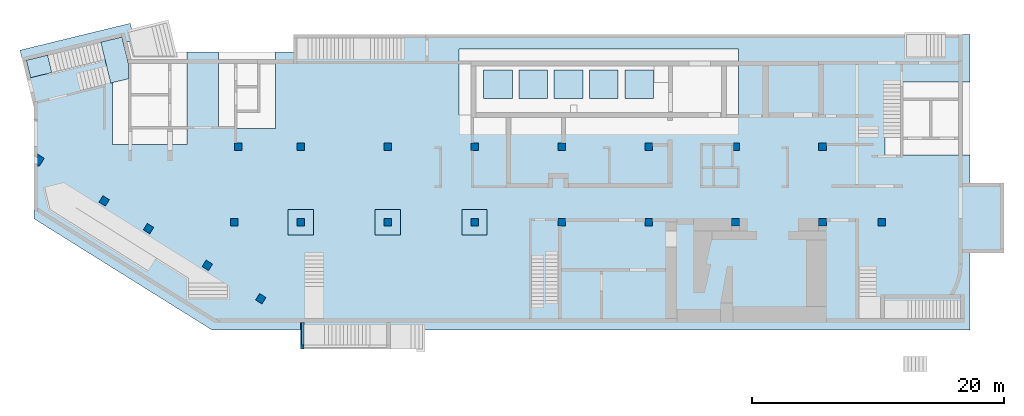
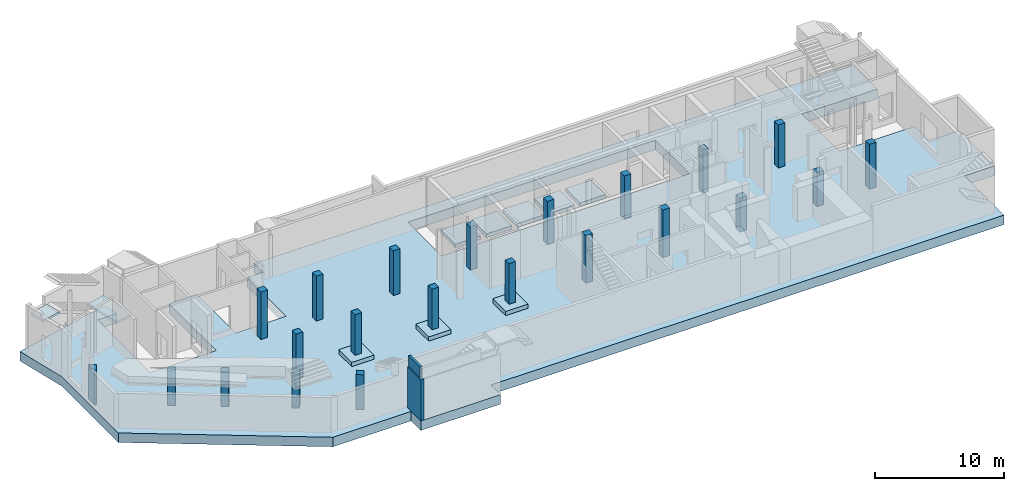
# One storey, part 1 of 9: 22 columns, 11 slabs, 2 walls.
"""IFC4 building model written with IfcOpenShell, lengths in millimetres."""

import ifcopenshell
import ifcopenshell.guid

model = None  # the IFC model being written
_history = None  # IfcOwnerHistory: only IFC2X3 demands one
_inside = {}  # id of a spatial element -> (the spatial element, [elements in it])
_under = {}  # id of a project, library or spatial element -> (it, [spatial elements below it])
_declared = {}  # id of a project -> (the project, [libraries it declares])
_typed = {}  # id of a type object -> (the type object, [elements of that type])
_made_of = {}  # id of a material, layer set ... -> (it, [elements and type objects made of it])


def new_model(schema):
    """Start an empty IFC model of exactly this schema.

    Asked for "IFC4X3", IfcOpenShell would pick the latest addendum, in which some entities
    have other attributes; the version numbers below select the first issue.
    IFC2X3 requires an IfcOwnerHistory on every rooted entity: one is made here for all.
    """
    global model, _history
    if schema == "IFC4X3":
        model = ifcopenshell.file(schema_version=(4, 3, 0, 0))
    else:
        model = ifcopenshell.file(schema=schema)
    _inside.clear()
    _under.clear()
    _declared.clear()
    _typed.clear()
    _made_of.clear()
    _history = None
    if model.schema == "IFC2X3":
        org = make("IfcOrganization", Name="unknown")
        user = make(
            "IfcPersonAndOrganization",
            ThePerson=make("IfcPerson", FamilyName="unknown"),
            TheOrganization=org,
        )
        app = make(
            "IfcApplication",
            ApplicationDeveloper=org,
            Version="unknown",
            ApplicationFullName="unknown",
            ApplicationIdentifier="unknown",
        )
        _history = make(
            "IfcOwnerHistory",
            OwningUser=user,
            OwningApplication=app,
            ChangeAction="ADDED",
            CreationDate=0,
        )
    return model


def make(cls, **values):
    """One entity of the class cls with the attributes given. An attribute that is None is left unset."""
    return model.create_entity(
        cls, **{name: value for name, value in values.items() if value is not None}
    )


def entity(cls, *values):
    """Any entity or typed value of the class cls, its attributes in the order of the schema. None: left unset."""
    e = model.create_entity(cls)
    for i, value in enumerate(values):
        if value is not None:
            e[i] = value
    return e


def rooted(cls, **values):
    """An entity with a GlobalId (a new one), such as an element, a storey or a relation."""
    return make(cls, GlobalId=ifcopenshell.guid.new(), OwnerHistory=_history, **values)


def si_unit(unit_type, name, prefix=None):
    """IfcSIUnit, for example si_unit("LENGTHUNIT", "METRE", prefix="MILLI")."""
    return make("IfcSIUnit", UnitType=unit_type, Prefix=prefix, Name=name)


def converted_unit(unit_type, name, factor, base, dimensions=None, offset=None):
    """IfcConversionBasedUnit, such as the inch: factor (a typed value) times the base unit."""
    return make(
        "IfcConversionBasedUnit"
        if offset is None
        else "IfcConversionBasedUnitWithOffset",
        ConversionOffset=offset,
        Dimensions=None
        if dimensions is None
        else entity("IfcDimensionalExponents", *dimensions),
        UnitType=unit_type,
        Name=name,
        ConversionFactor=make(
            "IfcMeasureWithUnit", ValueComponent=factor, UnitComponent=base
        ),
    )


def derived_unit(unit_type, elements):
    """IfcDerivedUnit: a product of units, each with its exponent."""
    return make(
        "IfcDerivedUnit",
        Elements=[
            make("IfcDerivedUnitElement", Unit=unit, Exponent=power)
            for unit, power in elements
        ],
        UnitType=unit_type,
    )


def assignment(units):
    """IfcUnitAssignment: the units of a project."""
    return None if units is None else make("IfcUnitAssignment", Units=units)


def point(xyz):
    """IfcCartesianPoint."""
    return None if xyz is None else make("IfcCartesianPoint", Coordinates=xyz)


def direction(xyz):
    """IfcDirection."""
    return None if xyz is None else make("IfcDirection", DirectionRatios=xyz)


def frame(location, z_axis=None, x_axis=None):
    """IfcAxis2Placement3D, a coordinate frame: its origin and axes. An axis left out is left unset."""
    return make(
        "IfcAxis2Placement3D",
        Location=point(location),
        Axis=direction(z_axis),
        RefDirection=direction(x_axis),
    )


def origin():
    """The frame at (0, 0, 0) with its axes left unset."""
    return frame((0.0, 0.0, 0.0))


def place(relative_to, where):
    """IfcLocalPlacement: puts the frame where relative to a parent placement (None: the world)."""
    return make(
        "IfcLocalPlacement", PlacementRelTo=relative_to, RelativePlacement=where
    )


def context(
    kind, dimensions, precision=None, world=None, true_north=None, identifier=None
):
    """IfcGeometricRepresentationContext, for example the 3D "Model" context."""
    return make(
        "IfcGeometricRepresentationContext",
        ContextIdentifier=identifier,
        ContextType=kind,
        CoordinateSpaceDimension=dimensions,
        Precision=precision,
        WorldCoordinateSystem=world,
        TrueNorth=true_north,
    )


def subcontext(parent, identifier, kind, view, scale=None):
    """IfcGeometricRepresentationSubContext, for example "Body" below "Model"."""
    return make(
        "IfcGeometricRepresentationSubContext",
        ContextIdentifier=identifier,
        ContextType=kind,
        ParentContext=parent,
        TargetScale=scale,
        TargetView=view,
    )


def project(units=None, contexts=None):
    """IfcProject with its units and contexts."""
    return rooted(
        "IfcProject",
        Name="project",
        RepresentationContexts=contexts,
        UnitsInContext=assignment(units),
    )


def spatial(cls, under=None, at=None, **own):
    """A site, building, storey or space (cls), placed at a placement, below another one or the project."""
    s = rooted(cls, ObjectPlacement=at, **own)
    if under is not None:
        _under.setdefault(under.id(), (under, []))[1].append(s)
    return s


def point_list(points):
    """IfcCartesianPointList2D or 3D."""
    cls = (
        "IfcCartesianPointList2D" if len(points[0]) == 2 else "IfcCartesianPointList3D"
    )
    return make(cls, CoordList=points)


def indexed_curve(points, segments=None, self_intersect=None):
    """IfcIndexedPolyCurve: lines and arcs through numbered points (the first is 1)."""
    return make(
        "IfcIndexedPolyCurve",
        Points=point_list(points),
        Segments=segments,
        SelfIntersect=self_intersect,
    )


def outline(outer, holes=None, kind="AREA"):
    """IfcArbitraryClosedProfileDef: a profile drawn as a closed curve; with holes, ...WithVoids."""
    if holes is None:
        return make("IfcArbitraryClosedProfileDef", ProfileType=kind, OuterCurve=outer)
    return make(
        "IfcArbitraryProfileDefWithVoids",
        ProfileType=kind,
        OuterCurve=outer,
        InnerCurves=holes,
    )


def extrude(swept, where, along, depth):
    """IfcExtrudedAreaSolid: the profile swept, set in the frame where, extruded along a direction by depth."""
    return make(
        "IfcExtrudedAreaSolid",
        SweptArea=swept,
        Position=where,
        ExtrudedDirection=direction(along),
        Depth=depth,
    )


def shape(context_of_items, identifier, shape_type, items):
    """IfcShapeRepresentation: the items that make up one representation, for example the "Body"."""
    return make(
        "IfcShapeRepresentation",
        ContextOfItems=context_of_items,
        RepresentationIdentifier=identifier,
        RepresentationType=shape_type,
        Items=items,
    )


def source(mapping_origin, context_of_items, identifier, shape_type, items):
    """IfcRepresentationMap: a shape defined once, which mapped items show again and again."""
    return make(
        "IfcRepresentationMap",
        MappingOrigin=mapping_origin,
        MappedRepresentation=shape(context_of_items, identifier, shape_type, items),
    )


def transform(
    local_origin,
    x_axis=None,
    y_axis=None,
    z_axis=None,
    scale=None,
    scale2=None,
    scale3=None,
    uniform=True,
):
    """IfcCartesianTransformationOperator3D, or its non-uniform kind. x_axis, y_axis, z_axis: its Axis1, 2, 3."""
    if uniform:
        return make(
            "IfcCartesianTransformationOperator3D",
            Axis1=direction(x_axis),
            Axis2=direction(y_axis),
            LocalOrigin=point(local_origin),
            Scale=scale,
            Axis3=direction(z_axis),
        )
    return make(
        "IfcCartesianTransformationOperator3DnonUniform",
        Axis1=direction(x_axis),
        Axis2=direction(y_axis),
        LocalOrigin=point(local_origin),
        Scale=scale,
        Axis3=direction(z_axis),
        Scale2=scale2,
        Scale3=scale3,
    )


def mapped(mapping_source, mapping_target):
    """IfcMappedItem: shows the shape of a source again, moved by a transform."""
    return make(
        "IfcMappedItem", MappingSource=mapping_source, MappingTarget=mapping_target
    )


def material(Name=None, Category=None):
    """IfcMaterial."""
    return make("IfcMaterial", Name=Name, Category=Category)


def constituent(of_material, Name=None, Category=None, fraction=None):
    """IfcMaterialConstituent: one of the materials an element consists of."""
    return make(
        "IfcMaterialConstituent",
        Name=Name,
        Material=of_material,
        Fraction=fraction,
        Category=Category,
    )


def constituent_set(constituents=None, Name=None):
    """IfcMaterialConstituentSet."""
    return make(
        "IfcMaterialConstituentSet", Name=Name, MaterialConstituents=constituents
    )


def made_of(thing, what):
    """Note that an element or type object is made of a material, layer set ...; save() writes the relation."""
    if what is not None:
        _made_of.setdefault(what.id(), (what, []))[1].append(thing)
    return thing


def type_object(cls, material=None, **own):
    """A type object (cls), such as IfcWallType, which elements share."""
    return made_of(rooted(cls, **own), material)


def type_shapes(of_type, sources):
    """Give a type object the sources (RepresentationMaps) that its elements show as mapped items."""
    of_type.RepresentationMaps = sources


def element(
    cls,
    number,
    at=None,
    inside=None,
    cuts=None,
    type_object=None,
    material=None,
    context=None,
    identifier="Body",
    shape_type=None,
    held_by="IfcProductDefinitionShape",
    body=None,
    shapes=None,
    **own,
):
    """One element of the class cls, such as IfcWall. Its Tag is "e" and its number.

    at: its placement. inside: the storey or other place that contains it. cuts: it is an
    opening in that element (IfcRelVoidsElement). A single representation is given by context,
    identifier, shape_type and body (its items); several are given by shapes. held_by: the class
    of the entity that holds the representations. save() writes the other relations.
    """
    e = rooted(cls, Tag="e%d" % number, ObjectPlacement=at, **own)
    if body is not None:
        shapes = [shape(context, identifier, shape_type, body)]
    if shapes is not None:
        e.Representation = make(held_by, Representations=shapes)
    if inside is not None:
        _inside.setdefault(inside.id(), (inside, []))[1].append(e)
    if cuts is not None:
        rooted(
            "IfcRelVoidsElement", RelatingBuildingElement=cuts, RelatedOpeningElement=e
        )
    if type_object is not None:
        _typed.setdefault(type_object.id(), (type_object, []))[1].append(e)
    return made_of(e, material)


def aggregate(whole, parts):
    """IfcRelAggregates: a whole, such as a stair, and the parts it consists of."""
    return rooted("IfcRelAggregates", RelatingObject=whole, RelatedObjects=parts)


def save(model, path):
    """Write the relations noted so far, then the file.

    IfcRelAggregates (storeys below a building ...), IfcRelContainedInSpatialStructure (elements
    in a storey), IfcRelDefinesByType, IfcRelAssociatesMaterial and IfcRelDeclares: one each for
    every whole, place, type object, material and project.
    """
    for whole, parts in _under.values():
        aggregate(whole, parts)
    for where, things in _inside.values():
        rooted(
            "IfcRelContainedInSpatialStructure",
            RelatedElements=things,
            RelatingStructure=where,
        )
    for kind, things in _typed.values():
        rooted("IfcRelDefinesByType", RelatedObjects=things, RelatingType=kind)
    for what, things in _made_of.values():
        rooted("IfcRelAssociatesMaterial", RelatedObjects=things, RelatingMaterial=what)
    for by, libraries in _declared.values():
        rooted("IfcRelDeclares", RelatingContext=by, RelatedDefinitions=libraries)
    model.write(path)


model = new_model("IFC4")

# Units and contexts
model_context = context("Model", 3, precision=0.01, world=origin(), true_north=direction((6.12303176911189e-17, 1.0)))
plan_context = context("Plan", 3, precision=0.01, world=origin(), true_north=direction((6.12303176911189e-17, 1.0)))
body_context = subcontext(model_context, "Body", "Model", "MODEL_VIEW")
ifc_project = project(units=[si_unit("LENGTHUNIT", "METRE", prefix="MILLI"), si_unit("AREAUNIT", "SQUARE_METRE"), si_unit("VOLUMEUNIT", "CUBIC_METRE"), converted_unit("PLANEANGLEUNIT", "DEGREE", entity("IfcRatioMeasure", 0.0174532925199433), si_unit("PLANEANGLEUNIT", "RADIAN"), dimensions=[0, 0, 0, 0, 0, 0, 0]), si_unit("MASSUNIT", "GRAM", prefix="KILO"), derived_unit("MASSDENSITYUNIT", [(si_unit("MASSUNIT", "GRAM", prefix="KILO"), 1), (si_unit("LENGTHUNIT", "METRE"), -3)]), derived_unit("MOMENTOFINERTIAUNIT", [(si_unit("LENGTHUNIT", "METRE"), 4)]), si_unit("TIMEUNIT", "SECOND"), si_unit("FREQUENCYUNIT", "HERTZ"), si_unit("THERMODYNAMICTEMPERATUREUNIT", "DEGREE_CELSIUS"), derived_unit("THERMALTRANSMITTANCEUNIT", [(si_unit("MASSUNIT", "GRAM", prefix="KILO"), 1), (si_unit("THERMODYNAMICTEMPERATUREUNIT", "KELVIN"), -1), (si_unit("TIMEUNIT", "SECOND"), -3)]), derived_unit("VOLUMETRICFLOWRATEUNIT", [(si_unit("LENGTHUNIT", "METRE"), 3), (si_unit("TIMEUNIT", "SECOND"), -1)]), derived_unit("MASSFLOWRATEUNIT", [(si_unit("MASSUNIT", "GRAM", prefix="KILO"), 1), (si_unit("TIMEUNIT", "SECOND"), -1)]), derived_unit("ROTATIONALFREQUENCYUNIT", [(si_unit("TIMEUNIT", "SECOND"), -1)]), si_unit("ELECTRICCURRENTUNIT", "AMPERE"), si_unit("ELECTRICVOLTAGEUNIT", "VOLT"), si_unit("POWERUNIT", "WATT"), si_unit("FORCEUNIT", "NEWTON", prefix="KILO"), si_unit("ILLUMINANCEUNIT", "LUX"), si_unit("LUMINOUSFLUXUNIT", "LUMEN"), si_unit("LUMINOUSINTENSITYUNIT", "CANDELA"), derived_unit("USERDEFINED", [(si_unit("MASSUNIT", "GRAM", prefix="KILO"), -1), (si_unit("LENGTHUNIT", "METRE"), -2), (si_unit("TIMEUNIT", "SECOND"), 3), (si_unit("LUMINOUSFLUXUNIT", "LUMEN"), 1)]), derived_unit("LINEARVELOCITYUNIT", [(si_unit("LENGTHUNIT", "METRE"), 1), (si_unit("TIMEUNIT", "SECOND"), -1)]), si_unit("PRESSUREUNIT", "PASCAL"), derived_unit("USERDEFINED", [(si_unit("LENGTHUNIT", "METRE"), -2), (si_unit("MASSUNIT", "GRAM", prefix="KILO"), 1), (si_unit("TIMEUNIT", "SECOND"), -2)]), derived_unit("LINEARFORCEUNIT", [(si_unit("MASSUNIT", "GRAM", prefix="KILO"), 1), (si_unit("LENGTHUNIT", "METRE"), 1), (si_unit("TIMEUNIT", "SECOND"), -2), (si_unit("LENGTHUNIT", "METRE"), -1)]), derived_unit("PLANARFORCEUNIT", [(si_unit("MASSUNIT", "GRAM", prefix="KILO"), 1), (si_unit("LENGTHUNIT", "METRE"), 1), (si_unit("TIMEUNIT", "SECOND"), -2), (si_unit("LENGTHUNIT", "METRE"), -2)])], contexts=[model_context, plan_context])

# Site, building, storey
site_placement = place(None, origin())
site = spatial("IfcSite", under=ifc_project, at=site_placement, CompositionType="ELEMENT")
building_placement = place(site_placement, origin())
building = spatial("IfcBuilding", under=site, at=building_placement, CompositionType="ELEMENT")
storey_placement = place(building_placement, frame((0.0, 0.0, -4900.0)))
storey = spatial("IfcBuildingStorey", under=building, at=storey_placement, CompositionType="ELEMENT", Elevation=-4900.0)

# Columns
ifc_material_1 = material()
column_type_1 = type_object("IfcColumnType", PredefinedType="COLUMN", material=ifc_material_1)
shared_shape_1 = source(origin(), body_context, "Body", "SweptSolid", [
    extrude(outline(indexed_curve([(-300.0, -300.000000000001), (300.0, -300.000000000001), (300.0, 299.999999999999), (-300.0, 299.999999999999), (-300.0, -300.000000000001)], self_intersect=False)), frame((15900.0002685547, 7699.99922635634, -4900.0), z_axis=(0.0, 0.0, 1.0), x_axis=(0.0, -1.0, 0.0)), (0.0, 0.0, 1.0), 4250.0),
])
type_shapes(column_type_1, [shared_shape_1])
column_1_placement = place(storey_placement, frame((0.0, 0.0, 4900.0)))
element("IfcColumn", 1, at=column_1_placement, inside=storey, type_object=column_type_1, PredefinedType="COLUMN", context=body_context, shape_type="MappedRepresentation", body=[
    mapped(shared_shape_1, transform((0.0, 0.0, 0.0), scale=1.0)),
])
column_type_2 = type_object("IfcColumnType", PredefinedType="COLUMN", material=ifc_material_1)
shared_shape_2 = source(origin(), body_context, "Body", "SweptSolid", [
    extrude(outline(indexed_curve([(-300.000000000001, -300.000000000001), (299.999999999999, -300.000000000001), (299.999999999999, 299.999999999999), (-300.000000000001, 299.999999999999), (-300.000000000001, -300.000000000001)], self_intersect=False)), frame((16200.0002685547, 13699.9992263563, -4900.0), z_axis=(0.0, 0.0, 1.0), x_axis=(0.0, -1.0, 0.0)), (0.0, 0.0, 1.0), 4500.0),
])
type_shapes(column_type_2, [shared_shape_2])
column_2_placement = place(storey_placement, frame((0.0, 0.0, 4900.0)))
element("IfcColumn", 2, at=column_2_placement, inside=storey, type_object=column_type_2, PredefinedType="COLUMN", context=body_context, shape_type="MappedRepresentation", body=[
    mapped(shared_shape_2, transform((0.0, 0.0, 0.0), scale=1.0)),
])
column_type_3 = type_object("IfcColumnType", PredefinedType="COLUMN", material=ifc_material_1)
shared_shape_3 = source(origin(), body_context, "Body", "SweptSolid", [
    extrude(outline(indexed_curve([(-299.999999999999, -300.000000000001), (300.000000000001, -300.000000000001), (299.999999999999, 299.999999999997), (-300.000000000001, 300.000000000001), (-299.999999999999, -300.000000000001)], self_intersect=False)), frame((21170.0002685547, 13699.9992263563, -4900.0), z_axis=(0.0, 0.0, 1.0), x_axis=(0.0, -1.0, 0.0)), (0.0, 0.0, 1.0), 4250.0),
])
type_shapes(column_type_3, [shared_shape_3])
column_3_placement = place(storey_placement, frame((0.0, 0.0, 4900.0)))
element("IfcColumn", 3, at=column_3_placement, inside=storey, type_object=column_type_3, PredefinedType="COLUMN", context=body_context, shape_type="MappedRepresentation", body=[
    mapped(shared_shape_3, transform((0.0, 0.0, 0.0), scale=1.0)),
])
column_type_4 = type_object("IfcColumnType", PredefinedType="COLUMN", material=ifc_material_1)
shared_shape_4 = source(origin(), body_context, "Body", "SweptSolid", [
    extrude(outline(indexed_curve([(-299.999999999997, -300.000000000001), (300.000000000003, -300.000000000001), (300.000000000001, 299.999999999997), (-299.999999999999, 300.000000000001), (-299.999999999997, -300.000000000001)], self_intersect=False)), frame((28070.0002685547, 13699.9992263563, -4900.0), z_axis=(0.0, 0.0, 1.0), x_axis=(0.0, -1.0, 0.0)), (0.0, 0.0, 1.0), 4250.0),
])
type_shapes(column_type_4, [shared_shape_4])
column_4_placement = place(storey_placement, frame((0.0, 0.0, 4900.0)))
element("IfcColumn", 4, at=column_4_placement, inside=storey, type_object=column_type_4, PredefinedType="COLUMN", context=body_context, shape_type="MappedRepresentation", body=[
    mapped(shared_shape_4, transform((0.0, 0.0, 0.0), scale=1.0)),
])
column_type_5 = type_object("IfcColumnType", PredefinedType="COLUMN", material=ifc_material_1)
shared_shape_5 = source(origin(), body_context, "Body", "SweptSolid", [
    extrude(outline(indexed_curve([(-299.999999999999, -300.000000000001), (300.000000000001, -300.000000000001), (299.999999999999, 299.999999999997), (-300.000000000001, 300.000000000001), (-299.999999999999, -300.000000000001)], self_intersect=False)), frame((34970.0002685546, 13699.9992263563, -4900.0), z_axis=(0.0, 0.0, 1.0), x_axis=(0.0, -1.0, 0.0)), (0.0, 0.0, 1.0), 4100.0),
])
type_shapes(column_type_5, [shared_shape_5])
column_5_placement = place(storey_placement, frame((0.0, 0.0, 4900.0)))
element("IfcColumn", 5, at=column_5_placement, inside=storey, type_object=column_type_5, PredefinedType="COLUMN", context=body_context, shape_type="MappedRepresentation", body=[
    mapped(shared_shape_5, transform((0.0, 0.0, 0.0), scale=1.0)),
])
column_type_6 = type_object("IfcColumnType", PredefinedType="COLUMN", material=ifc_material_1)
shared_shape_6 = source(origin(), body_context, "Body", "SweptSolid", [
    extrude(outline(indexed_curve([(-300.000000000001, -300.000000000001), (299.999999999999, -300.000000000001), (299.999999999997, 300.000000000001), (-300.000000000003, 300.000000000001), (-300.000000000001, -300.000000000001)], self_intersect=False)), frame((41870.0002685547, 13699.9992263563, -4900.0), z_axis=(0.0, 0.0, 1.0), x_axis=(0.0, -1.0, 0.0)), (0.0, 0.0, 1.0), 4100.0),
])
type_shapes(column_type_6, [shared_shape_6])
column_6_placement = place(storey_placement, frame((0.0, 0.0, 4900.0)))
element("IfcColumn", 6, at=column_6_placement, inside=storey, type_object=column_type_6, PredefinedType="COLUMN", context=body_context, shape_type="MappedRepresentation", body=[
    mapped(shared_shape_6, transform((0.0, 0.0, 0.0), scale=1.0)),
])
column_type_7 = type_object("IfcColumnType", PredefinedType="COLUMN", material=ifc_material_1)
shared_shape_7 = source(origin(), body_context, "Body", "SweptSolid", [
    extrude(outline(indexed_curve([(-299.999999999999, -300.000000000001), (300.000000000001, -300.000000000001), (299.999999999999, 300.000000000001), (-300.000000000001, 300.000000000001), (-299.999999999999, -300.000000000001)], self_intersect=False)), frame((48770.0002685547, 13699.9992263562, -4900.0), z_axis=(0.0, 0.0, 1.0), x_axis=(0.0, -1.0, 0.0)), (0.0, 0.0, 1.0), 4100.0),
])
type_shapes(column_type_7, [shared_shape_7])
column_7_placement = place(storey_placement, frame((0.0, 0.0, 4900.0)))
element("IfcColumn", 7, at=column_7_placement, inside=storey, type_object=column_type_7, PredefinedType="COLUMN", context=body_context, shape_type="MappedRepresentation", body=[
    mapped(shared_shape_7, transform((0.0, 0.0, 0.0), scale=1.0)),
])
column_type_8 = type_object("IfcColumnType", PredefinedType="COLUMN", material=ifc_material_1)
shared_shape_8 = source(origin(), body_context, "Body", "SweptSolid", [
    extrude(outline(indexed_curve([(-299.999999999997, -225.000000000001), (300.000000000003, -225.000000000001), (300.000000000001, 225.000000000018), (-299.999999999999, 225.000000000018), (-299.999999999997, -225.000000000001)], self_intersect=False)), frame((55745.0002685546, 13699.9992263562, -4900.0), z_axis=(0.0, 0.0, 1.0), x_axis=(0.0, -1.0, 0.0)), (0.0, 0.0, 1.0), 4100.0),
])
type_shapes(column_type_8, [shared_shape_8])
column_8_placement = place(storey_placement, frame((0.0, 0.0, 4900.0)))
element("IfcColumn", 8, at=column_8_placement, inside=storey, type_object=column_type_8, PredefinedType="COLUMN", context=body_context, shape_type="MappedRepresentation", body=[
    mapped(shared_shape_8, transform((0.0, 0.0, 0.0), scale=1.0)),
])
column_type_9 = type_object("IfcColumnType", PredefinedType="COLUMN", material=ifc_material_1)
shared_shape_9 = source(origin(), body_context, "Body", "SweptSolid", [
    extrude(outline(indexed_curve([(-299.999999999999, -300.000000000001), (300.000000000001, -300.000000000001), (299.999999999999, 300.000000000001), (-300.000000000001, 300.000000000001), (-299.999999999999, -300.000000000001)], self_intersect=False)), frame((62570.0002685547, 13699.9992263562, -4900.0), z_axis=(0.0, 0.0, 1.0), x_axis=(0.0, -1.0, 0.0)), (0.0, 0.0, 1.0), 4100.0),
])
type_shapes(column_type_9, [shared_shape_9])
column_9_placement = place(storey_placement, frame((0.0, 0.0, 4900.0)))
element("IfcColumn", 9, at=column_9_placement, inside=storey, type_object=column_type_9, PredefinedType="COLUMN", context=body_context, shape_type="MappedRepresentation", body=[
    mapped(shared_shape_9, transform((0.0, 0.0, 0.0), scale=1.0)),
])
column_type_10 = type_object("IfcColumnType", PredefinedType="COLUMN", material=ifc_material_1)
shared_shape_10 = source(origin(), body_context, "Body", "SweptSolid", [
    extrude(outline(indexed_curve([(-300.0, -300.000000000001), (300.0, -300.000000000001), (300.0, 300.000000000001), (-300.0, 300.000000000001), (-300.0, -300.000000000001)], self_intersect=False)), frame((41870.0002685547, 7699.99922635609, -4900.0), z_axis=(0.0, 0.0, 1.0), x_axis=(0.0, -1.0, 0.0)), (0.0, 0.0, 1.0), 4500.0),
])
type_shapes(column_type_10, [shared_shape_10])
column_10_placement = place(storey_placement, frame((0.0, 0.0, 4900.0)))
element("IfcColumn", 10, at=column_10_placement, inside=storey, type_object=column_type_10, PredefinedType="COLUMN", context=body_context, shape_type="MappedRepresentation", body=[
    mapped(shared_shape_10, transform((0.0, 0.0, 0.0), scale=1.0)),
])
column_type_11 = type_object("IfcColumnType", PredefinedType="COLUMN", material=ifc_material_1)
shared_shape_11 = source(origin(), body_context, "Body", "SweptSolid", [
    extrude(outline(indexed_curve([(-300.0, -300.000000000001), (300.0, -300.000000000001), (300.0, 300.000000000001), (-300.0, 300.000000000001), (-300.0, -300.000000000001)], self_intersect=False)), frame((48770.0002685546, 7699.99922635606, -4900.0), z_axis=(0.0, 0.0, 1.0), x_axis=(0.0, -1.0, 0.0)), (0.0, 0.0, 1.0), 4500.0),
])
type_shapes(column_type_11, [shared_shape_11])
column_11_placement = place(storey_placement, frame((0.0, 0.0, 4900.0)))
element("IfcColumn", 11, at=column_11_placement, inside=storey, type_object=column_type_11, PredefinedType="COLUMN", context=body_context, shape_type="MappedRepresentation", body=[
    mapped(shared_shape_11, transform((0.0, 0.0, 0.0), scale=1.0)),
])
column_type_12 = type_object("IfcColumnType", PredefinedType="COLUMN", material=ifc_material_1)
shared_shape_12 = source(origin(), body_context, "Body", "SweptSolid", [
    extrude(outline(indexed_curve([(-300.0, -300.000000000001), (300.0, -300.000000000001), (300.0, 300.000000000001), (-300.0, 300.000000000001), (-300.0, -300.000000000001)], self_intersect=False)), frame((55670.0002685547, 7699.99922635604, -4900.0), z_axis=(0.0, 0.0, 1.0), x_axis=(0.0, -1.0, 0.0)), (0.0, 0.0, 1.0), 3200.0),
])
type_shapes(column_type_12, [shared_shape_12])
column_12_placement = place(storey_placement, frame((0.0, 0.0, 4900.0)))
element("IfcColumn", 12, at=column_12_placement, inside=storey, type_object=column_type_12, PredefinedType="COLUMN", context=body_context, shape_type="MappedRepresentation", body=[
    mapped(shared_shape_12, transform((0.0, 0.0, 0.0), scale=1.0)),
])
column_type_13 = type_object("IfcColumnType", PredefinedType="COLUMN", material=ifc_material_1)
shared_shape_13 = source(origin(), body_context, "Body", "SweptSolid", [
    extrude(outline(indexed_curve([(-300.0, -300.000000000001), (300.0, -300.000000000001), (300.0, 300.000000000001), (-300.0, 300.000000000001), (-300.0, -300.000000000001)], self_intersect=False)), frame((62570.0002685546, 7699.99922635602, -4900.0), z_axis=(0.0, 0.0, 1.0), x_axis=(0.0, -1.0, 0.0)), (0.0, 0.0, 1.0), 3200.0),
])
type_shapes(column_type_13, [shared_shape_13])
column_13_placement = place(storey_placement, frame((0.0, 0.0, 4900.0)))
element("IfcColumn", 13, at=column_13_placement, inside=storey, type_object=column_type_13, PredefinedType="COLUMN", context=body_context, shape_type="MappedRepresentation", body=[
    mapped(shared_shape_13, transform((0.0, 0.0, 0.0), scale=1.0)),
])
column_type_14 = type_object("IfcColumnType", PredefinedType="COLUMN", material=ifc_material_1)
shared_shape_14 = source(origin(), body_context, "Body", "SweptSolid", [
    extrude(outline(indexed_curve([(-300.0, -300.000000000001), (300.0, -300.000000000001), (300.0, 299.999999999997), (-300.0, 300.000000000001), (-300.0, -300.000000000001)], self_intersect=False)), frame((21170.0002685546, 7699.99922635626, -4500.0), z_axis=(0.0, 0.0, 1.0), x_axis=(0.0, -1.0, 0.0)), (0.0, 0.0, 1.0), 3850.0),
])
type_shapes(column_type_14, [shared_shape_14])
column_14_placement = place(storey_placement, frame((0.0, 0.0, 4900.0)))
element("IfcColumn", 14, at=column_14_placement, inside=storey, type_object=column_type_14, PredefinedType="COLUMN", context=body_context, shape_type="MappedRepresentation", body=[
    mapped(shared_shape_14, transform((0.0, 0.0, 0.0), scale=1.0)),
])
column_type_15 = type_object("IfcColumnType", PredefinedType="COLUMN", material=ifc_material_1)
shared_shape_15 = source(origin(), body_context, "Body", "SweptSolid", [
    extrude(outline(indexed_curve([(-300.0, -300.000000000001), (300.0, -300.000000000001), (300.0, 299.999999999997), (-300.0, 300.000000000001), (-300.0, -300.000000000001)], self_intersect=False)), frame((28070.0002685546, 7699.99922635623, -4500.0), z_axis=(0.0, 0.0, 1.0), x_axis=(0.0, -1.0, 0.0)), (0.0, 0.0, 1.0), 3850.0),
])
type_shapes(column_type_15, [shared_shape_15])
column_15_placement = place(storey_placement, frame((0.0, 0.0, 4900.0)))
element("IfcColumn", 15, at=column_15_placement, inside=storey, type_object=column_type_15, PredefinedType="COLUMN", context=body_context, shape_type="MappedRepresentation", body=[
    mapped(shared_shape_15, transform((0.0, 0.0, 0.0), scale=1.0)),
])
column_type_16 = type_object("IfcColumnType", PredefinedType="COLUMN", material=ifc_material_1)
shared_shape_16 = source(origin(), body_context, "Body", "SweptSolid", [
    extrude(outline(indexed_curve([(-300.0, -300.000000000001), (300.0, -300.000000000001), (300.0, 299.999999999997), (-300.0, 300.000000000001), (-300.0, -300.000000000001)], self_intersect=False)), frame((34970.0002685546, 7699.99922635621, -4500.0), z_axis=(0.0, 0.0, 1.0), x_axis=(0.0, -1.0, 0.0)), (0.0, 0.0, 1.0), 3850.0),
])
type_shapes(column_type_16, [shared_shape_16])
column_16_placement = place(storey_placement, frame((0.0, 0.0, 4900.0)))
element("IfcColumn", 16, at=column_16_placement, inside=storey, type_object=column_type_16, PredefinedType="COLUMN", context=body_context, shape_type="MappedRepresentation", body=[
    mapped(shared_shape_16, transform((0.0, 0.0, 0.0), scale=1.0)),
])
column_type_17 = type_object("IfcColumnType", PredefinedType="COLUMN", material=ifc_material_1)
shared_shape_17 = source(origin(), body_context, "Body", "SweptSolid", [
    extrude(outline(indexed_curve([(-300.0, -300.0), (300.0, -300.0), (300.0, 300.0), (-300.0, 300.0), (-300.0, -300.0)], self_intersect=False)), frame((18003.0383058692, 1625.88709185487, -4900.0), z_axis=(0.0, 0.0, 1.0), x_axis=(-0.848052743777573, 0.529911826412028, 0.0)), (0.0, 0.0, 1.0), 3280.0),
])
type_shapes(column_type_17, [shared_shape_17])
column_17_placement = place(storey_placement, frame((0.0, 0.0, 4900.0)))
element("IfcColumn", 17, at=column_17_placement, inside=storey, type_object=column_type_17, PredefinedType="COLUMN", context=body_context, shape_type="MappedRepresentation", body=[
    mapped(shared_shape_17, transform((0.0, 0.0, 0.0), scale=1.0)),
])
column_type_18 = type_object("IfcColumnType", PredefinedType="COLUMN", material=ifc_material_1)
shared_shape_18 = source(origin(), body_context, "Body", "SweptSolid", [
    extrude(outline(indexed_curve([(-300.0, -300.0), (300.0, -300.0), (300.0, 300.0), (-300.0, 300.0), (-300.0, -300.0)], self_intersect=False)), frame((13762.7745869814, 4275.446223915, -4900.0), z_axis=(0.0, 0.0, 1.0), x_axis=(-0.848052743777572, 0.529911826412028, 0.0)), (0.0, 0.0, 1.0), 3280.0),
])
type_shapes(column_type_18, [shared_shape_18])
column_18_placement = place(storey_placement, frame((0.0, 0.0, 4900.0)))
element("IfcColumn", 18, at=column_18_placement, inside=storey, type_object=column_type_18, PredefinedType="COLUMN", context=body_context, shape_type="MappedRepresentation", body=[
    mapped(shared_shape_18, transform((0.0, 0.0, 0.0), scale=1.0)),
])
column_type_19 = type_object("IfcColumnType", PredefinedType="COLUMN", material=ifc_material_1)
shared_shape_19 = source(origin(), body_context, "Body", "SweptSolid", [
    extrude(outline(indexed_curve([(-300.0, -300.0), (300.0, -300.0), (300.0, 300.0), (-300.0, 300.0), (-300.0, -300.0)], self_intersect=False)), frame((9098.48449620471, 7189.96126918114, -4900.0), z_axis=(0.0, 0.0, 1.0), x_axis=(-0.848052743777572, 0.529911826412028, 0.0)), (0.0, 0.0, 1.0), 3280.0),
])
type_shapes(column_type_19, [shared_shape_19])
column_19_placement = place(storey_placement, frame((0.0, 0.0, 4900.0)))
element("IfcColumn", 19, at=column_19_placement, inside=storey, type_object=column_type_19, PredefinedType="COLUMN", context=body_context, shape_type="MappedRepresentation", body=[
    mapped(shared_shape_19, transform((0.0, 0.0, 0.0), scale=1.0)),
])
column_type_20 = type_object("IfcColumnType", PredefinedType="COLUMN", material=ifc_material_1)
shared_shape_20 = source(origin(), body_context, "Body", "SweptSolid", [
    extrude(outline(indexed_curve([(-300.0, -300.0), (300.0, -300.0), (300.0, 300.0), (-300.0, 300.0), (-300.0, -300.0)], self_intersect=False)), frame((5579.06560952777, 9389.09534879104, -4900.0), z_axis=(0.0, 0.0, 1.0), x_axis=(-0.848052743777572, 0.529911826412028, 0.0)), (0.0, 0.0, 1.0), 3280.0),
])
type_shapes(column_type_20, [shared_shape_20])
column_20_placement = place(storey_placement, frame((0.0, 0.0, 4900.0)))
element("IfcColumn", 20, at=column_20_placement, inside=storey, type_object=column_type_20, PredefinedType="COLUMN", context=body_context, shape_type="MappedRepresentation", body=[
    mapped(shared_shape_20, transform((0.0, 0.0, 0.0), scale=1.0)),
])
column_type_21 = type_object("IfcColumnType", PredefinedType="COLUMN", material=ifc_material_1)
shared_shape_21 = source(origin(), body_context, "Body", "SweptSolid", [
    extrude(outline(indexed_curve([(-300.0, -300.000000000001), (300.0, -300.000000000001), (300.0, 300.000000000001), (-300.0, 300.000000000001), (-300.0, -300.000000000001)], self_intersect=False)), frame((67270.0002685546, 7699.99922635611, -4900.0), z_axis=(0.0, 0.0, 1.0), x_axis=(0.0, -1.0, 0.0)), (0.0, 0.0, 1.0), 4250.0),
])
type_shapes(column_type_21, [shared_shape_21])
column_21_placement = place(storey_placement, frame((0.0, 0.0, 4900.0)))
element("IfcColumn", 21, at=column_21_placement, inside=storey, type_object=column_type_21, PredefinedType="COLUMN", context=body_context, shape_type="MappedRepresentation", body=[
    mapped(shared_shape_21, transform((0.0, 0.0, 0.0), scale=1.0)),
])
ifc_material_2 = material()
ifc_constituent_1 = constituent(ifc_material_2)
ifc_material_3 = material()
ifc_constituent_2 = constituent(ifc_material_3)
ifc_constituent_set = constituent_set(constituents=[ifc_constituent_1, ifc_constituent_2])
column_type_22 = type_object("IfcColumnType", PredefinedType="COLUMN", material=ifc_constituent_set)
shared_shape_22 = source(origin(), body_context, "Body", "SweptSolid", [
    extrude(outline(indexed_curve([(-543.222538329964, -170.163318495476), (378.949872142256, -170.163318495476), (378.949872142255, -15.3027456556089), (-214.677205954544, 355.62938264656), (-543.222538329964, -170.163318495476)], self_intersect=False)), frame((470.163587050136, 12557.5548401597, -4900.0), z_axis=(0.0, 0.0, 1.0), x_axis=(0.0, -1.0, 0.0)), (0.0, 0.0, 1.0), 3280.0),
])
type_shapes(column_type_22, [shared_shape_22])
column_22_placement = place(storey_placement, frame((0.0, 0.0, 4900.0)))
element("IfcColumn", 22, at=column_22_placement, inside=storey, type_object=column_type_22, PredefinedType="COLUMN", context=body_context, shape_type="MappedRepresentation", body=[
    mapped(shared_shape_22, transform((0.0, 0.0, 0.0), scale=1.0)),
])

# Slabs
slab_type_1 = type_object("IfcSlabType", PredefinedType="BASESLAB", material=ifc_material_1)
slab_1_placement = place(storey_placement, origin())
element("IfcSlab", 23, at=slab_1_placement, inside=storey, type_object=slab_type_1, material=ifc_material_1, PredefinedType="BASESLAB", context=body_context, shape_type="SweptSolid", body=[
    extrude(outline(indexed_curve([(40677.8945979547, -7707.60946829249), (43377.8945979547, -7707.60946829249), (43377.8945979547, -2182.60946829252), (40677.8945979547, -2182.60946829252), (40677.8945979547, 37.3905317075305), (33927.8945979547, 37.3905317075305), (33927.8945979547, 5837.39053170749), (40677.8945979547, 5837.39053170749), (40677.8945979547, 9617.3905317075), (-13002.1054020453, 9617.3905317075), (-13002.1054020453, 8217.39053170733), (-14417.1054020453, 8217.39053170733), (-14417.1054020453, 2167.3905317073), (-18942.1054020453, 2167.3905317073), (-18942.1054020453, 8217.39053170732), (-21442.1054020453, 8217.39053170732), (-21442.1054020453, 867.390531707281), (-27342.1054020453, 867.390531707254), (-27342.1054020453, 9067.39053170725), (-25598.7931104971, 9067.39053170726), (-25947.2001078711, 10496.6905344877), (-34691.1609264089, 8365.25757568542), (-33592.1054020453, 3856.50753372621), (-33592.1054020453, -5000.60946829221), (-19458.1054020453, -13832.6094682925), (-12452.1054020453, -13832.6094682925), (-12452.1054020453, -15332.6094682925), (-5302.10540204527, -15332.6094682925), (-5302.10540204527, -13832.6094682925), (40677.8945979547, -13832.6094682925), (40677.8945979547, -7707.60946829249)], self_intersect=False), holes=[indexed_curve([(22327.8945979547, 8467.39053170756), (22327.8945979547, 3217.39053170756), (127.894597954704, 3217.39053170745), (127.89459795467, 8467.39053170745), (22327.8945979547, 8467.39053170756)], self_intersect=False)]), frame((33592.1056705999, 12982.6086946486, -900.0)), (0.0, 0.0, 1.0), 900.0),
])
slab_type_2 = type_object("IfcSlabType", PredefinedType="BASESLAB", material=ifc_material_1)
slab_2_placement = place(storey_placement, origin())
element("IfcSlab", 24, at=slab_2_placement, inside=storey, type_object=slab_type_2, material=ifc_material_1, PredefinedType="BASESLAB", context=body_context, shape_type="SweptSolid", body=[
    extrude(outline(indexed_curve([(-1140.0, -1140.0), (1140.00000000001, -1140.0), (1140.0, 1140.00000000001), (-1140.00000000001, 1140.0), (-1140.0, -1140.0)], self_intersect=False)), frame((36825.0002685547, 18649.9992263562, -400.0), z_axis=(0.0, 0.0, -1.0), x_axis=(0.0, 1.0, 0.0)), (0.0, 0.0, 1.0), 349.999999999999),
])
slab_type_3 = type_object("IfcSlabType", PredefinedType="BASESLAB", material=ifc_material_1)
slab_3_placement = place(storey_placement, origin())
element("IfcSlab", 25, at=slab_3_placement, inside=storey, type_object=slab_type_3, material=ifc_material_1, PredefinedType="BASESLAB", context=body_context, shape_type="SweptSolid", body=[
    extrude(outline(indexed_curve([(-1140.0, -1140.0), (1140.00000000001, -1140.0), (1140.0, 1140.00000000001), (-1140.00000000001, 1140.0), (-1140.0, -1140.0)], self_intersect=False)), frame((39625.0002685547, 18649.9992263562, -400.0), z_axis=(0.0, 0.0, -1.0), x_axis=(0.0, 1.0, 0.0)), (0.0, 0.0, 1.0), 349.999999999999),
])
slab_type_4 = type_object("IfcSlabType", PredefinedType="BASESLAB", material=ifc_material_1)
slab_4_placement = place(storey_placement, origin())
element("IfcSlab", 26, at=slab_4_placement, inside=storey, type_object=slab_type_4, material=ifc_material_1, PredefinedType="BASESLAB", context=body_context, shape_type="SweptSolid", body=[
    extrude(outline(indexed_curve([(-1140.0, -1140.0), (1140.00000000001, -1140.0), (1140.0, 1140.00000000001), (-1140.00000000001, 1140.0), (-1140.0, -1140.0)], self_intersect=False)), frame((42425.0002685547, 18649.9992263562, -400.0), z_axis=(0.0, 0.0, -1.0), x_axis=(0.0, 1.0, 0.0)), (0.0, 0.0, 1.0), 349.999999999999),
])
slab_type_5 = type_object("IfcSlabType", PredefinedType="BASESLAB", material=ifc_material_1)
slab_5_placement = place(storey_placement, origin())
element("IfcSlab", 27, at=slab_5_placement, inside=storey, type_object=slab_type_5, material=ifc_material_1, PredefinedType="BASESLAB", context=body_context, shape_type="SweptSolid", body=[
    extrude(outline(indexed_curve([(-1140.0, -1140.0), (1140.00000000001, -1140.0), (1140.0, 1140.00000000001), (-1140.00000000001, 1140.0), (-1140.0, -1140.0)], self_intersect=False)), frame((45225.0002685547, 18649.9992263562, -400.0), z_axis=(0.0, 0.0, -1.0), x_axis=(0.0, 1.0, 0.0)), (0.0, 0.0, 1.0), 349.999999999999),
])
slab_type_6 = type_object("IfcSlabType", PredefinedType="BASESLAB", material=ifc_material_1)
slab_6_placement = place(storey_placement, origin())
element("IfcSlab", 28, at=slab_6_placement, inside=storey, type_object=slab_type_6, material=ifc_material_1, PredefinedType="BASESLAB", context=body_context, shape_type="SweptSolid", body=[
    extrude(outline(indexed_curve([(-1140.0, -1140.0), (1140.00000000001, -1140.0), (1140.0, 1140.00000000001), (-1140.00000000001, 1140.0), (-1140.0, -1140.0)], self_intersect=False)), frame((48025.0002685547, 18649.9992263562, -400.0), z_axis=(0.0, 0.0, -1.0), x_axis=(0.0, 1.0, 0.0)), (0.0, 0.0, 1.0), 349.999999999999),
])
slab_type_7 = type_object("IfcSlabType", PredefinedType="BASESLAB", material=ifc_material_1)
slab_7_placement = place(storey_placement, origin())
element("IfcSlab", 29, at=slab_7_placement, inside=storey, type_object=slab_type_7, material=ifc_material_1, PredefinedType="BASESLAB", context=body_context, shape_type="SweptSolid", body=[
    extrude(outline(indexed_curve([(-1000.0, -1000.0), (1000.0, -1000.0), (1000.0, 999.999999999998), (-1000.0, 999.999999999998), (-1000.0, -1000.0)], self_intersect=False)), frame((21170.0002685547, 7699.9992263563, 400.0), z_axis=(0.0, 0.0, -1.0), x_axis=(0.0, 1.0, 0.0)), (0.0, 0.0, 1.0), 400.0),
])
slab_type_8 = type_object("IfcSlabType", PredefinedType="BASESLAB", material=ifc_material_1)
slab_8_placement = place(storey_placement, origin())
element("IfcSlab", 30, at=slab_8_placement, inside=storey, type_object=slab_type_8, material=ifc_material_1, PredefinedType="BASESLAB", context=body_context, shape_type="SweptSolid", body=[
    extrude(outline(indexed_curve([(-1000.0, -999.999999999998), (1000.0, -999.999999999998), (1000.0, 1000.0), (-1000.0, 1000.0), (-1000.0, -999.999999999998)], self_intersect=False)), frame((28070.0002685546, 7699.99922635628, 400.0), z_axis=(0.0, 0.0, -1.0), x_axis=(0.0, 1.0, 0.0)), (0.0, 0.0, 1.0), 400.0),
])
slab_type_9 = type_object("IfcSlabType", PredefinedType="BASESLAB", material=ifc_material_1)
slab_9_placement = place(storey_placement, origin())
element("IfcSlab", 31, at=slab_9_placement, inside=storey, type_object=slab_type_9, material=ifc_material_1, PredefinedType="BASESLAB", context=body_context, shape_type="SweptSolid", body=[
    extrude(outline(indexed_curve([(-1000.0, -999.999999999998), (1000.0, -999.999999999998), (1000.0, 1000.0), (-1000.0, 1000.0), (-1000.0, -999.999999999998)], self_intersect=False)), frame((34970.0002685546, 7699.99922635625, 400.0), z_axis=(0.0, 0.0, -1.0), x_axis=(0.0, 1.0, 0.0)), (0.0, 0.0, 1.0), 400.0),
])
slab_type_10 = type_object("IfcSlabType", PredefinedType="FLOOR", material=ifc_material_1)
slab_10_placement = place(storey_placement, origin())
element("IfcSlab", 32, at=slab_10_placement, inside=storey, type_object=slab_type_10, material=ifc_material_1, PredefinedType="FLOOR", context=body_context, shape_type="SweptSolid", body=[
    extrude(outline(indexed_curve([(199.032465229822, -820.264699289819), (1419.20577821791, -820.264699289819), (1760.47954860354, 579.772052662983), (-1484.50432558899, 1370.7712032507), (-1894.21346646227, -310.013857334047), (199.032465229822, -820.264699289819)], self_intersect=False)), frame((6679.73556926486, 20499.0316915862, 1870.0), z_axis=(0.0, 0.0, -1.0), x_axis=(0.0, -1.0, 0.0)), (0.0, 0.0, 1.0), 200.0),
])
slab_type_11 = type_object("IfcSlabType", PredefinedType="FLOOR", material=ifc_material_1)
slab_11_placement = place(storey_placement, origin())
element("IfcSlab", 33, at=slab_11_placement, inside=storey, type_object=slab_type_11, material=ifc_material_1, PredefinedType="FLOOR", context=body_context, shape_type="SweptSolid", body=[
    extrude(outline(indexed_curve([(-864.999999999999, -709.999999999996), (865.000000000001, -709.999999999996), (864.999999999999, 709.999999999996), (-865.000000000001, 709.999999999996), (-864.999999999999, -709.999999999996)], self_intersect=False)), frame((414.092901640345, 20059.5698550601, 3970.0), z_axis=(0.0, 0.0, -1.0), x_axis=(0.971552058141474, 0.236826092990334, 0.0)), (0.0, 0.0, 1.0), 200.0),
])

# Walls
wall_type_1 = type_object("IfcWallType", PredefinedType="STANDARD")
wall_1_placement = place(storey_placement, frame((21340.0002685546, -192.080816499762, 3870.0), z_axis=(0.0, 0.0, 1.0), x_axis=(0.0, -1.0, 0.0)))
element("IfcWall", 34, at=wall_1_placement, inside=storey, type_object=wall_type_1, material=ifc_material_1, PredefinedType="NOTDEFINED", context=body_context, shape_type="SweptSolid", body=[
    extrude(outline(indexed_curve([(1857.91995714394, -100.000000000003), (1857.91995714394, 99.9999999999989), (57.9199571439329, 99.9999999999989), (57.9199571439315, -100.000000000003), (1857.91995714394, -100.000000000003)], self_intersect=False)), origin(), (0.0, 0.0, 1.0), 999.999999999997),
])
wall_type_2 = type_object("IfcWallType", PredefinedType="STANDARD")
wall_2_placement = place(storey_placement, frame((21290.0002685546, -2350.00077364371, 0.0), z_axis=(0.0, 0.0, 1.0), x_axis=(0.0, 1.0, 0.0)))
element("IfcWall", 35, at=wall_2_placement, inside=storey, type_object=wall_type_2, material=ifc_material_1, PredefinedType="NOTDEFINED", context=body_context, shape_type="SweptSolid", body=[
    extrude(outline(indexed_curve([(2100.00000000001, 150.000000000001), (0.0, 150.000000000001), (0.0, -150.000000000001), (2100.00000000001, -150.000000000001), (2100.00000000001, 150.000000000001)], self_intersect=False)), origin(), (0.0, 0.0, 1.0), 3870.0),
])

save(model, "model.ifc")
